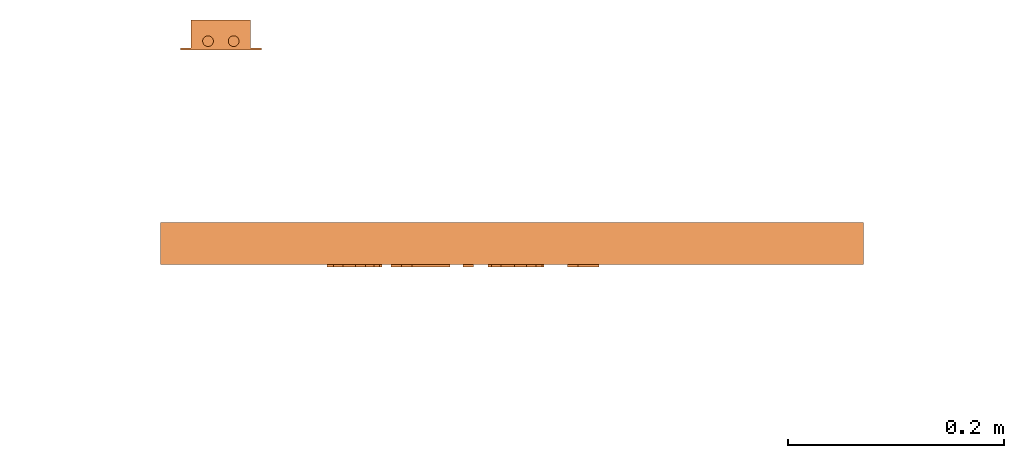
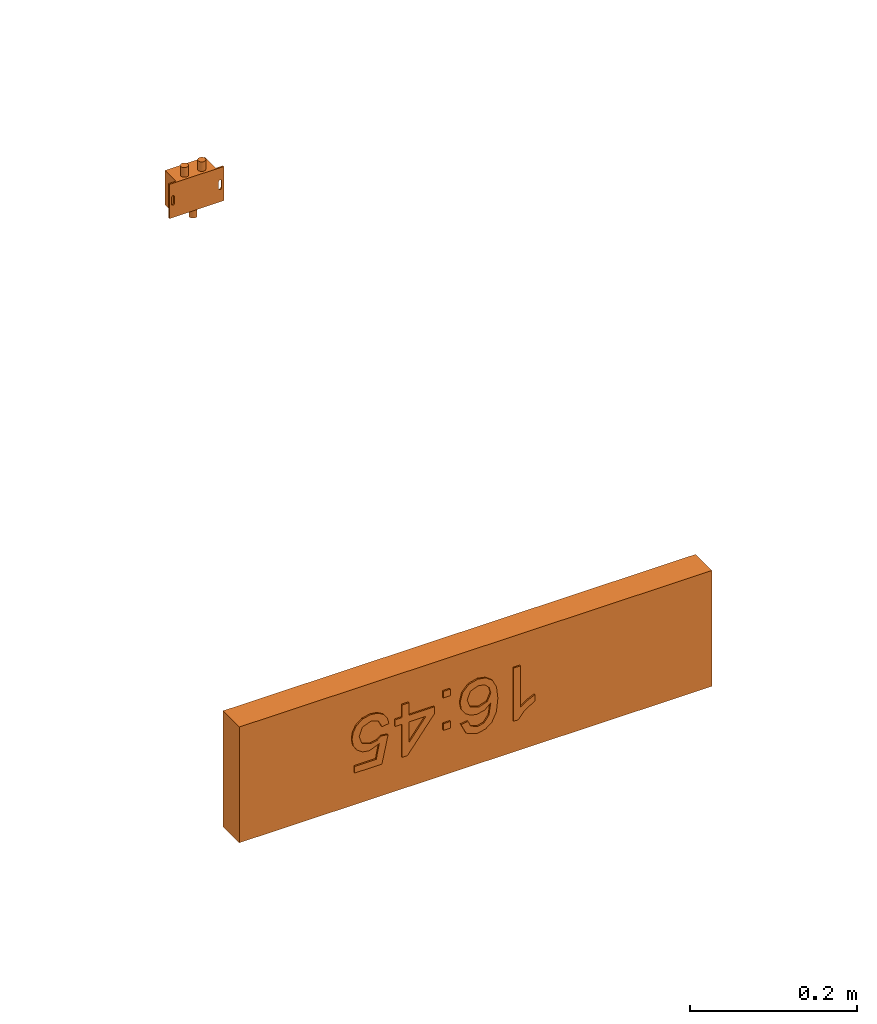
# One storey, part 5 of 6: 2 proxies.
"""IFC2X3 building model written with IfcOpenShell, lengths in millimetres."""

from ifc_helpers import new_model, entity, si_unit, converted_unit, derived_unit, direction, frame, frame_2d, origin, origin_2d_with_axis, place, context, subcontext, project, spatial, polyline, circle_curve, parameter, trimmed, segment, composite_curve, rectangle, circle, outline, extrude, source, transform, mapped, material, material_list, type_object, type_shapes, element, save


model = new_model("IFC2X3")

# Units and contexts
model_context = context("Model", 3, precision=0.01, world=origin(), true_north=direction((6.12303176911189e-17, 1.0)))
body_context = subcontext(model_context, "Body", "Model", "MODEL_VIEW")
ifc_project = project(units=[si_unit("LENGTHUNIT", "METRE", prefix="MILLI"), si_unit("AREAUNIT", "SQUARE_METRE"), si_unit("VOLUMEUNIT", "CUBIC_METRE"), converted_unit("PLANEANGLEUNIT", "DEGREE", entity("IfcRatioMeasure", 0.0174532925199433), si_unit("PLANEANGLEUNIT", "RADIAN"), dimensions=[0, 0, 0, 0, 0, 0, 0]), si_unit("MASSUNIT", "GRAM", prefix="KILO"), derived_unit("MASSDENSITYUNIT", [(si_unit("MASSUNIT", "GRAM", prefix="KILO"), 1), (si_unit("LENGTHUNIT", "METRE"), -3)]), derived_unit("MOMENTOFINERTIAUNIT", [(si_unit("LENGTHUNIT", "METRE"), 4)]), si_unit("TIMEUNIT", "SECOND"), si_unit("FREQUENCYUNIT", "HERTZ"), si_unit("THERMODYNAMICTEMPERATUREUNIT", "DEGREE_CELSIUS"), derived_unit("THERMALTRANSMITTANCEUNIT", [(si_unit("MASSUNIT", "GRAM", prefix="KILO"), 1), (si_unit("THERMODYNAMICTEMPERATUREUNIT", "KELVIN"), -1), (si_unit("TIMEUNIT", "SECOND"), -3)]), derived_unit("VOLUMETRICFLOWRATEUNIT", [(si_unit("LENGTHUNIT", "METRE"), 3), (si_unit("TIMEUNIT", "SECOND"), -1)]), derived_unit("MASSFLOWRATEUNIT", [(si_unit("MASSUNIT", "GRAM", prefix="KILO"), 1), (si_unit("TIMEUNIT", "SECOND"), -1)]), derived_unit("ROTATIONALFREQUENCYUNIT", [(si_unit("TIMEUNIT", "SECOND"), -1)]), si_unit("ELECTRICCURRENTUNIT", "AMPERE"), si_unit("ELECTRICVOLTAGEUNIT", "VOLT"), si_unit("POWERUNIT", "WATT"), si_unit("FORCEUNIT", "NEWTON", prefix="KILO"), si_unit("ILLUMINANCEUNIT", "LUX"), si_unit("LUMINOUSFLUXUNIT", "LUMEN"), si_unit("LUMINOUSINTENSITYUNIT", "CANDELA"), derived_unit("USERDEFINED", [(si_unit("MASSUNIT", "GRAM", prefix="KILO"), -1), (si_unit("LENGTHUNIT", "METRE"), -2), (si_unit("TIMEUNIT", "SECOND"), 3), (si_unit("LUMINOUSFLUXUNIT", "LUMEN"), 1)]), derived_unit("LINEARVELOCITYUNIT", [(si_unit("LENGTHUNIT", "METRE"), 1), (si_unit("TIMEUNIT", "SECOND"), -1)]), si_unit("PRESSUREUNIT", "PASCAL"), derived_unit("USERDEFINED", [(si_unit("LENGTHUNIT", "METRE"), -2), (si_unit("MASSUNIT", "GRAM", prefix="KILO"), 1), (si_unit("TIMEUNIT", "SECOND"), -2)]), derived_unit("LINEARFORCEUNIT", [(si_unit("MASSUNIT", "GRAM", prefix="KILO"), 1), (si_unit("LENGTHUNIT", "METRE"), 1), (si_unit("TIMEUNIT", "SECOND"), -2), (si_unit("LENGTHUNIT", "METRE"), -1)]), derived_unit("PLANARFORCEUNIT", [(si_unit("MASSUNIT", "GRAM", prefix="KILO"), 1), (si_unit("LENGTHUNIT", "METRE"), 1), (si_unit("TIMEUNIT", "SECOND"), -2), (si_unit("LENGTHUNIT", "METRE"), -2)])], contexts=[model_context])

# Site, building, storey
site_placement = place(None, frame((0.0, -0.00077364408347762, 0.0)))
site = spatial("IfcSite", under=ifc_project, at=site_placement, CompositionType="ELEMENT")
building_placement = place(site_placement, origin())
building = spatial("IfcBuilding", under=site, at=building_placement, CompositionType="ELEMENT")
storey_placement = place(building_placement, frame((0.0, 0.0, 19800.0)))
storey = spatial("IfcBuildingStorey", under=building, at=storey_placement, CompositionType="ELEMENT", Elevation=19800.0)

# Proxies
ifc_material_1 = material()
ifc_material_2 = material()
ifc_material_list_1 = material_list([ifc_material_1, ifc_material_2])
ifc_material_list_2 = material_list([ifc_material_1, ifc_material_1, ifc_material_1, ifc_material_1, ifc_material_1, ifc_material_1, ifc_material_2])
building_element_proxy_type_1 = type_object("IfcBuildingElementProxyType", PredefinedType="NOTDEFINED", material=ifc_material_list_2)
shared_shape_1 = source(origin(), body_context, "Body", "SweptSolid", [
    extrude(outline(polyline([(-49.3297558922559, -13.0650252525253), (28.2460016835017, -13.0650252525253), (28.2460016835017, -6.81502525252525), (17.924031986532, 1.81186868686869), (8.85206228956228, 16.0258838383838), (-0.314604377104382, 16.0258838383838), (4.58122895622896, 5.8175505050505), (11.1247895622896, -3.36805555555555), (-49.3297558922559, -3.36805555555555), (-49.3297558922559, -13.0650252525253)])), frame((-64.5801773123525, 9.80013072699887, 39.0), z_axis=(0.0, 0.0, 1.0), x_axis=(0.0, 1.0, 0.0)), (0.0, 0.0, 1.0), 2.0),
    extrude(outline(polyline([(2.24011853050057, -27.5618774069986), (18.9807108648058, -27.5618774069986), (30.4808593810603, -16.0523867195033), (33.2951509700614, -4.93311916754034), (31.0144130646924, 5.7575762787575), (21.7987736055003, 17.1572643136776), (5.24761200604798, 27.3340921309932), (-11.0974111566595, 32.9532554648861), (-23.9746782077303, 32.7048013849557), (-33.6281248088369, 27.5788768374718), (-40.3016866216521, 18.5656287687041), (-42.7660378318467, 5.67274679265255), (-37.9721755114974, -6.33783567611335), (-27.2455737728681, -14.9533745518323), (-17.5348420919177, -17.6670021030155), (-8.19356542843746, -16.4449721815935), (-0.291454529980238, -11.8654762653203), (5.1017798559014, -4.50670583194971), (7.34785423483786, 6.15330079609256), (4.01114564454941, 17.1916653593814), (18.4548387600492, 7.30997301607691), (23.5935364768699, -2.44380014762508), (21.9745124884661, -11.3576456930974), (14.1729209955885, -18.4151203904576), (5.29132308249511, -18.2779876016039), (2.24011853050057, -27.5618774069986)]), holes=[polyline([(-8.96594443465761, 23.331014608368), (-1.26018519149069, 14.3532201865936), (-2.5541294758174, 1.98565321334379), (-11.3601436525543, -6.99563380914675), (-23.3897211552763, -6.05015679749623), (-32.1796543698203, 2.91675270916293), (-31.2121825444575, 15.1035400981067), (-25.5825280165424, 22.1095150051529), (-17.5185200759943, 24.8943605417974), (-8.96594443465761, 23.331014608368)])]), frame((-2.74431872649391, 3.62832938019752, 39.0), z_axis=(0.0, 0.0, 1.0), x_axis=(-0.427648602040224, 0.903945060926294, 0.0)), (0.0, 0.0, 1.0), 2.0),
    extrude(rectangle(XDim=9.6969696969697, YDim=9.6969696969697, at=origin_2d_with_axis()), frame((40.6060600613849, -34.6811403167722, 39.0)), (0.0, 0.0, 1.0), 2.0),
    extrude(rectangle(XDim=9.6969696969697, YDim=9.6969696969697, at=origin_2d_with_axis()), frame((40.6060600613849, 12.5915869559551, 39.0)), (0.0, 0.0, 1.0), 2.0),
    extrude(outline(polyline([(-0.881542699724549, -28.099173553719), (8.81542699724518, -28.099173553719), (8.81542699724518, -9.91735537190083), (18.5123966942148, -9.91735537190083), (18.5123966942148, -0.220385674931129), (8.81542699724518, -0.220385674931129), (8.81542699724518, 48.2644628099173), (1.54269972451788, 48.2644628099173), (-36.0330578512397, -0.220385674931129), (-36.0330578512397, -9.91735537190083), (-0.881542699724549, -9.91735537190083), (-0.881542699724549, -28.099173553719)]), holes=[polyline([(-0.881542699724549, -0.220385674931129), (-24.1012396694215, -0.220385674931129), (-0.881542699724549, 29.7417355371901), (-0.881542699724549, -0.220385674931129)])]), frame((93.6088148823215, -11.430451611538, 39.0)), (0.0, 0.0, 1.0), 2.0),
    extrude(outline(polyline([(3.28300438653322, -28.2688849771477), (12.486486021848, -28.2688849771477), (20.5381191721727, -25.0278768228724), (26.8189712884816, -18.8467250057334), (30.7101098217491, -10.0262940171423), (31.3981318926443, 1.60805822132837), (26.9015703293825, 11.8381634310008), (20.0564059210334, 18.3764186541994), (11.0756486569987, 22.3371351079238), (1.04176214713842, 23.2585538509025), (-7.93780091536274, 20.406367606958), (-14.9085866775867, 14.4772629545935), (-18.9161412866151, 6.16792647231239), (-17.143675825551, -8.98191514451195), (-36.7240258370804, 0.516426480877832), (-29.0829385906137, 29.2527275669393), (-38.4542673524376, 31.7445980575068), (-48.1102655033866, -4.56930089456074), (-11.6339210401096, -23.0481793347475), (-7.97063445431417, -13.9883343842446), (-10.7994707393594, -7.60185176247611), (-10.2407841657114, 1.05867314396988), (-3.00292415200101, 11.8430863913258), (9.16948621404518, 12.8100644404395), (19.9796079835536, 5.44778336414573), (21.348514929029, -7.49781677359889), (15.5141589936472, -16.4311092462368), (4.60345878187273, -18.5860724040029), (3.28300438653322, -28.2688849771477)])), frame((147.081979974805, -8.48643658300594, 39.0), z_axis=(0.0, 0.0, 1.0), x_axis=(0.256974144339772, -0.966418278563088, 0.0)), (0.0, 0.0, 1.0), 2.0),
    extrude(rectangle(XDim=652.0, YDim=169.000000000001, at=origin_2d_with_axis()), frame((0.0, 0.0, 0.0), z_axis=(0.0, 0.0, 1.0), x_axis=(-1.0, 0.0, 0.0)), (0.0, 0.0, 1.0), 38.9999999999999),
])
type_shapes(building_element_proxy_type_1, [shared_shape_1])
proxy_1_placement = place(storey_placement, frame((39540.0152067852, 17340.0, 2215.49999999999), z_axis=(0.0, -1.0, 0.0), x_axis=(-1.0, 0.0, 0.0)))
element("IfcBuildingElementProxy", 1, at=proxy_1_placement, inside=storey, type_object=building_element_proxy_type_1, material=ifc_material_list_1, context=body_context, shape_type="MappedRepresentation", body=[
    mapped(shared_shape_1, transform((0.0, 0.0, 0.0), scale=1.0)),
])
ifc_material_3 = material()
ifc_material_list_3 = material_list([ifc_material_3, ifc_material_3, ifc_material_3, ifc_material_3, ifc_material_3, ifc_material_3])
building_element_proxy_type_2 = type_object("IfcBuildingElementProxyType", PredefinedType="NOTDEFINED", material=ifc_material_list_3)
shared_shape_2 = source(origin(), body_context, "Body", "SweptSolid", [
    extrude(circle(Radius=5.0, at=frame_2d((-9.06504078924755e-31, 7.40241201668823e-15), x_axis=(1.0, 0.0))), frame((11.9166791548928, 25.0, 8.37499999999769), z_axis=(0.0, 1.0, 0.0), x_axis=(-1.0, 0.0, 0.0)), (0.0, 0.0, 1.0), 13.9999999999909),
    extrude(circle(Radius=5.0, at=frame_2d((-9.06504078924755e-31, 7.40241201668823e-15), x_axis=(1.0, 0.0))), frame((-11.8480864125471, 25.0, 8.37499999999783), z_axis=(0.0, 1.0, 0.0), x_axis=(-1.0, 0.0, 0.0)), (0.0, 0.0, 1.0), 14.0),
    extrude(circle(Radius=5.0, at=frame_2d((2.8490128194778e-30, -2.32647234810202e-14), x_axis=(1.0, 0.0))), frame((0.0269135874528058, -39.0, 8.37499999999739), z_axis=(0.0, 1.0, 0.0), x_axis=(-1.0, 0.0, 0.0)), (0.0, 0.0, 1.0), 13.9999999999909),
    extrude(outline(polyline([(-5.0, -25.0), (5.0, -25.0), (5.0, 25.0), (-5.0, 25.0), (-5.0, -25.0)]), holes=[composite_curve([segment(polyline([(2.00468630441402, 5.0), (2.00468630441402, -5.0)]), True, "CONTINUOUS"), segment(trimmed(circle_curve(frame_2d((0.0, -5.0), x_axis=(-1.0, 0.0)), 2.00468630440306), [parameter(3.56222124323914e-13)], [parameter(180.0)], True, "PARAMETER"), False, "CONTINUOUS"), segment(polyline([(-2.0046863043921, -5.0), (-2.0046863043921, 5.0)]), True, "CONTINUOUS"), segment(trimmed(circle_curve(frame_2d((0.0, 5.0), x_axis=(-1.0, 0.0)), 2.00468630440306), [parameter(180.0)], [parameter(5.08888749034163e-13)], True, "PARAMETER"), False, "CONTINUOUS")], self_intersect=False)]), frame((32.5000000000068, 0.0, 0.0), z_axis=(0.0, 0.0, 1.0), x_axis=(-1.0, 0.0, 0.0)), (0.0, 0.0, 1.0), 2.0),
    extrude(outline(polyline([(-5.0, -25.0), (5.0, -25.0), (5.0, 25.0), (-5.0, 25.0), (-5.0, -25.0)]), holes=[composite_curve([segment(polyline([(-2.00468630441444, -5.0), (-2.00468630441444, 5.0)]), True, "CONTINUOUS"), segment(trimmed(circle_curve(frame_2d((0.0, 5.0), x_axis=(-1.0, 0.0)), 2.00468630440306), [parameter(180.0)], [parameter(5.08888749034163e-13)], True, "PARAMETER"), False, "CONTINUOUS"), segment(polyline([(2.00468630439168, 5.0), (2.00468630439169, -5.0)]), True, "CONTINUOUS"), segment(trimmed(circle_curve(frame_2d((0.0, -5.0), x_axis=(-1.0, 0.0)), 2.00468630440306), [parameter(4.57999874130747e-13)], [parameter(180.0)], True, "PARAMETER"), False, "CONTINUOUS")], self_intersect=False)]), frame((-32.4999999999936, 0.0, 0.0), z_axis=(0.0, 0.0, 1.0), x_axis=(-1.0, 0.0, 0.0)), (0.0, 0.0, 1.0), 2.0),
    extrude(rectangle(XDim=55.0, YDim=49.9999999999997, at=frame_2d((0.0, 1.77635683940025e-15), x_axis=(1.0, 0.0))), frame((0.0, 0.0, 0.0), z_axis=(0.0, 0.0, 1.0), x_axis=(-1.0, 0.0, 0.0)), (0.0, 0.0, 1.0), 28.0),
])
type_shapes(building_element_proxy_type_2, [shared_shape_2])
proxy_2_placement = place(storey_placement, frame((39269.9500399736, 17500.0, 2939.50000000001), z_axis=(0.0, 1.0, 0.0), x_axis=(-1.0, 0.0, 0.0)))
element("IfcBuildingElementProxy", 2, at=proxy_2_placement, inside=storey, type_object=building_element_proxy_type_2, material=ifc_material_3, context=body_context, shape_type="MappedRepresentation", body=[
    mapped(shared_shape_2, transform((0.0, 0.0, 0.0), scale=1.0)),
])

save(model, "model.ifc")
